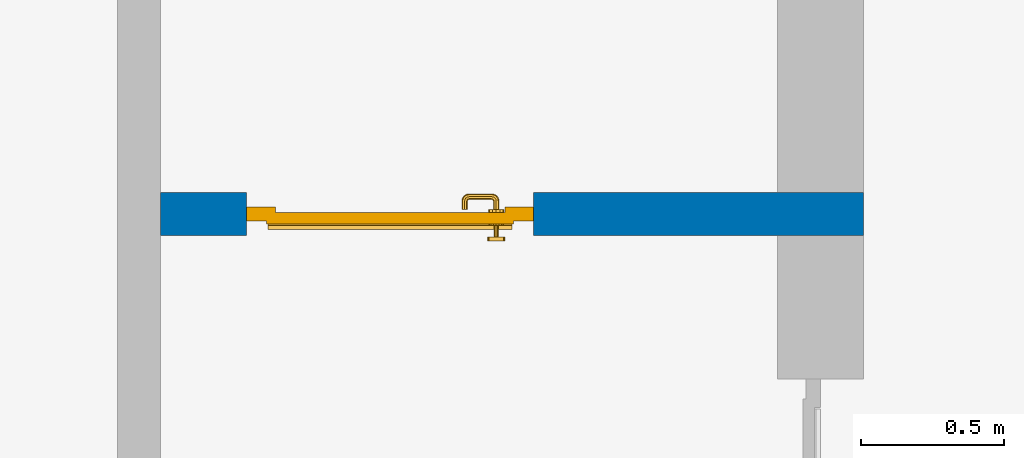
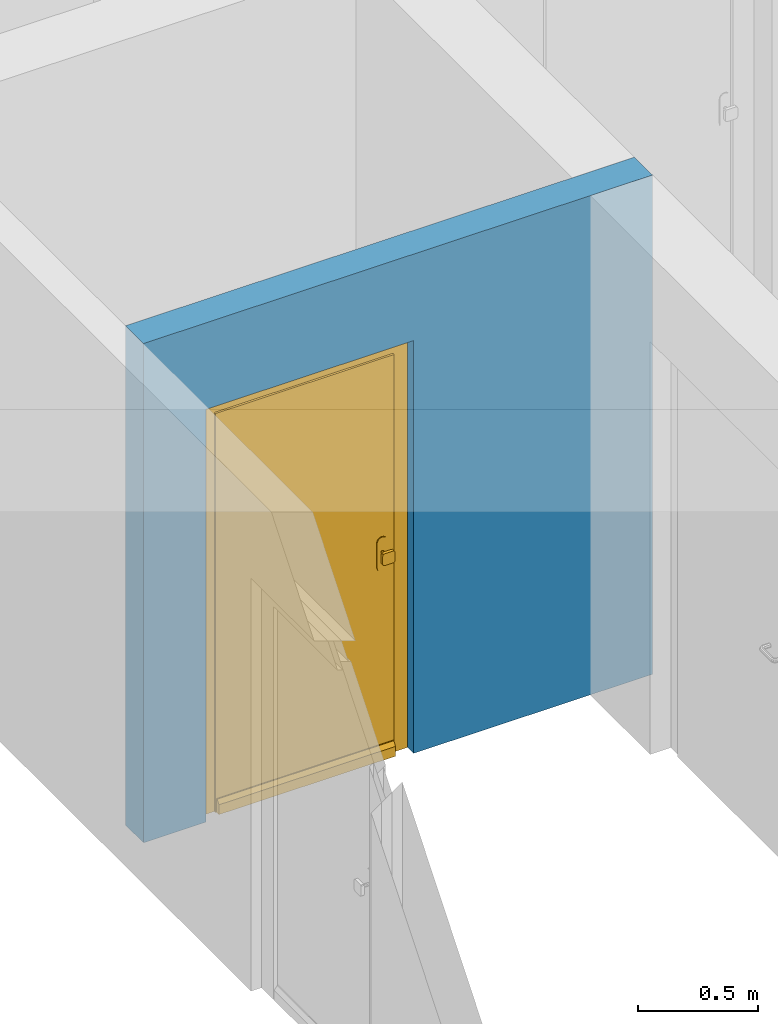
# One storey, part 5 of 54: 1 door, 1 wall, 1 opening.
"""IFC4 building model written with IfcOpenShell, lengths in metres."""

from ifc_helpers import new_model, entity, si_unit, converted_unit, derived_unit, direction, frame, origin_with_axes, place, context, subcontext, project, spatial, polygons, source, transform, mapped, material, type_object, element, fill, save


model = new_model("IFC4")

# Units and contexts
model_context = context("Model", 3, precision=1e-05, world=origin_with_axes(), true_north=direction((0.0, 1.0)))
body_context = subcontext(model_context, "Body", "Model", "MODEL_VIEW")
ifc_project = project(units=[si_unit("LENGTHUNIT", "METRE"), si_unit("AREAUNIT", "SQUARE_METRE"), si_unit("VOLUMEUNIT", "CUBIC_METRE"), converted_unit("PLANEANGLEUNIT", "DEGREE", entity("IfcPlaneAngleMeasure", 0.0174532925199), si_unit("PLANEANGLEUNIT", "RADIAN"), dimensions=[0, 0, 0, 0, 0, 0, 0]), converted_unit("TIMEUNIT", "Year", entity("IfcTimeMeasure", 31556926.0), si_unit("TIMEUNIT", "SECOND"), dimensions=[0, 0, 1, 0, 0, 0, 0]), si_unit("MASSUNIT", "GRAM", prefix="KILO"), si_unit("THERMODYNAMICTEMPERATUREUNIT", "DEGREE_CELSIUS"), si_unit("LUMINOUSINTENSITYUNIT", "LUMEN"), si_unit("ENERGYUNIT", "JOULE", prefix="MEGA"), derived_unit("THERMALCONDUCTANCEUNIT", [(si_unit("POWERUNIT", "WATT"), 1), (si_unit("LENGTHUNIT", "METRE"), -1), (si_unit("THERMODYNAMICTEMPERATUREUNIT", "KELVIN"), -1)]), derived_unit("SPECIFICHEATCAPACITYUNIT", [(si_unit("ENERGYUNIT", "JOULE"), 1), (si_unit("MASSUNIT", "GRAM", prefix="KILO"), -1), (si_unit("THERMODYNAMICTEMPERATUREUNIT", "KELVIN"), -1)]), derived_unit("MASSDENSITYUNIT", [(si_unit("MASSUNIT", "GRAM", prefix="KILO"), 1), (si_unit("VOLUMEUNIT", "CUBIC_METRE"), -1)])], contexts=[model_context])

# Site, building, storey
site_placement = place(None, origin_with_axes())
site = spatial("IfcSite", under=ifc_project, at=site_placement, CompositionType="ELEMENT")
building_placement = place(site_placement, origin_with_axes())
building = spatial("IfcBuilding", under=site, at=building_placement, CompositionType="ELEMENT")
storey_placement = place(building_placement, frame((0.0, 0.0, 9.18), z_axis=(0.0, 0.0, 1.0), x_axis=(1.0, 0.0, 0.0)))
storey = spatial("IfcBuildingStorey", under=building, at=storey_placement, Name="3. Geschoss", CompositionType="ELEMENT", Elevation=9.18)

# Wall, opening, door
ifc_material = material()
wall_type = type_object("IfcWallType", Name="150", PredefinedType="NOTDEFINED")
wall_placement = place(storey_placement, frame((-4.9421993804, -0.428812231043, 0.0), z_axis=(0.0, 0.0, 1.0), x_axis=(-1.0, 0.0, 0.0)))
wall = element("IfcWall", 1, at=wall_placement, inside=storey, type_object=wall_type, material=ifc_material, Name="Wand-002", PredefinedType="NOTDEFINED", context=body_context, shape_type="Tessellation", body=[
    polygons([(2.15, 0.0, 2.1), (2.15, 0.0, 0.0), (2.45, 0.0, 0.0), (2.45, 0.0, 2.54), (0.0, 0.0, 2.54), (0.0, 0.0, 0.0), (1.15, 0.0, 0.0), (1.15, 0.0, 2.1), (2.15, 0.1, 0.0), (2.15, 0.15, 2.1), (2.15, 0.15, 0.0), (2.45, 0.15, 0.0), (2.45, 0.15, 2.54), (0.0, 0.15, 2.54), (0.0, 0.15, 0.0), (1.15, 0.1, 0.0), (1.15, 0.15, 0.0), (1.15, 0.15, 2.1)], [[[1, 2, 3, 4, 5, 6, 7, 8]], [[9, 2, 1, 10, 11]], [[2, 9, 11, 12, 3]], [[4, 3, 12, 13]], [[5, 4, 13, 14]], [[14, 15, 6, 5]], [[16, 7, 6, 15, 17]], [[8, 7, 16, 17, 18]], [[1, 8, 18, 10]], [[12, 11, 10, 18, 17, 15, 14, 13]]], closed=True),
])
opening_placement = place(wall_placement, frame((1.65, 0.0, 0.0), z_axis=(0.0, 0.0, 1.0), x_axis=(1.0, 0.0, 0.0)))
opening = element("IfcOpeningElement", 2, at=opening_placement, cuts=wall, context=body_context, identifier="Reference", shape_type="Tessellation", body=[
    polygons([(-0.5, 0.1, 0.0), (-0.5, 0.1, 2.1), (-0.5, 0.151, 2.1), (-0.5, 0.151, 0.0), (-0.5, -0.001, 0.0), (-0.5, -0.001, 2.1), (0.5, 0.1, 2.1), (0.5, 0.151, 2.1), (0.5, -0.001, 2.1), (0.5, 0.151, 0.0), (0.5, 0.1, 0.0), (0.5, -0.001, 0.0)], [[[1, 2, 3, 4]], [[2, 1, 5, 6]], [[7, 8, 3, 2, 6, 9]], [[8, 10, 4, 3]], [[1, 4, 10, 11, 12, 5]], [[6, 5, 12, 9]], [[7, 11, 10, 8]], [[11, 7, 9, 12]]], closed=True),
])
door_type = type_object("IfcDoorType", Name="Eingang 01 1-Fl 26", OperationType="SINGLE_SWING_RIGHT", PredefinedType="DOOR")
shared_shape = source(origin_with_axes(), body_context, "Body", "Tessellation", [
    polygons([(0.5, -0.05, 0.0), (0.5, -0.03, 0.0), (0.5, -0.03, 2.1), (0.5, -0.05, 2.1), (0.4, -0.05, 0.0), (0.4, -0.03, 0.0), (0.4, -0.03, 2.0), (0.1301, -0.03, 2.0), (0.0001, -0.03, 2.0), (-0.4, -0.03, 2.0), (-0.4, -0.03, 0.0), (-0.5, -0.03, 0.0), (-0.5, -0.03, 2.1), (-0.5, -0.05, 2.1), (-0.5, -0.05, 0.0), (-0.4, -0.05, 0.0), (-0.4, -0.05, 2.0), (0.0001, -0.05, 2.0), (0.1301, -0.05, 2.0), (0.4, -0.05, 2.0)], [[[1, 2, 3, 4]], [[5, 6, 2, 1]], [[2, 6, 7, 8, 9, 10, 11, 12, 13, 3]], [[4, 3, 13, 14]], [[1, 4, 14, 15, 16, 17, 18, 19, 20, 5]], [[20, 7, 6, 5]], [[19, 8, 7, 20]], [[18, 9, 8, 19]], [[17, 10, 9, 18]], [[16, 11, 10, 17]], [[15, 12, 11, 16]], [[14, 13, 12, 15]]], closed=True),
    polygons([(0.5, -0.03, 0.0), (0.5, 0.0, 0.0), (0.5, 0.0, 2.1), (0.5, -0.03, 2.1), (0.43, -0.03, 0.0), (0.43, 0.0, 0.0), (0.43, 0.0, 2.03), (0.1001, 0.0, 2.03), (0.0301, 0.0, 2.03), (-0.43, 0.0, 2.03), (-0.43, 0.0, 0.0), (-0.5, 0.0, 0.0), (-0.5, 0.0, 2.1), (-0.5, -0.03, 2.1), (-0.5, -0.03, 0.0), (-0.43, -0.03, 0.0), (-0.43, -0.03, 2.03), (0.0301, -0.03, 2.03), (0.1001, -0.03, 2.03), (0.43, -0.03, 2.03)], [[[1, 2, 3, 4]], [[5, 6, 2, 1]], [[2, 6, 7, 8, 9, 10, 11, 12, 13, 3]], [[4, 3, 13, 14]], [[1, 4, 14, 15, 16, 17, 18, 19, 20, 5]], [[20, 7, 6, 5]], [[19, 8, 7, 20]], [[18, 9, 8, 19]], [[17, 10, 9, 18]], [[16, 11, 10, 17]], [[15, 12, 11, 16]], [[14, 13, 12, 15]]], closed=True),
    polygons([(0.43, 0.01, 0.0), (-0.43, 0.01, 0.0), (-0.43, 0.01, 2.03), (0.43, 0.01, 2.03), (0.43, -0.03, 0.0), (-0.43, -0.03, 0.0), (-0.43, -0.03, 2.03), (0.43, -0.03, 2.03)], [[[1, 2, 3, 4]], [[2, 1, 5, 6]], [[3, 2, 6, 7]], [[4, 3, 7, 8]], [[1, 4, 8, 5]], [[6, 5, 8, 7]]], closed=True),
    polygons([(0.425, 0.03, 0.0), (-0.425, 0.03, 0.0), (-0.425, 0.03, 0.05), (0.425, 0.03, 0.05), (0.425, 0.01, 0.0), (-0.425, 0.01, 0.0), (-0.425, 0.01, 0.07), (-0.425, 0.015, 0.07), (0.425, 0.015, 0.07), (0.425, 0.01, 0.07)], [[[1, 2, 3, 4]], [[5, 6, 2, 1]], [[2, 6, 7, 8, 3]], [[4, 3, 8, 9]], [[1, 4, 9, 10, 5]], [[10, 7, 6, 5]], [[9, 8, 7, 10]]], closed=True),
    polygons([(-0.3835, -0.04, 1.0733826859), (-0.37, -0.04, 1.077), (-0.37, -0.0399, 1.077), (-0.3835, -0.0399, 1.0733826859), (-0.393382685902, -0.04, 1.0635), (-0.397, -0.04, 1.05), (-0.393382685902, -0.04, 1.0365), (-0.3835, -0.04, 1.0266173141), (-0.37, -0.04, 1.023), (-0.3565, -0.04, 1.0266173141), (-0.346617314098, -0.04, 1.0365), (-0.343, -0.04, 1.05), (-0.346617314098, -0.04, 1.0635), (-0.3565, -0.04, 1.0733826859), (-0.3565, -0.0399, 1.0733826859), (-0.37, -0.0301, 1.077), (-0.3835, -0.0301, 1.0733826859), (-0.393382685902, -0.0399, 1.0635), (-0.397, -0.0399, 1.05), (-0.393382685902, -0.0399, 1.0365), (-0.3835, -0.0399, 1.0266173141), (-0.37, -0.0399, 1.023), (-0.3565, -0.0399, 1.0266173141), (-0.346617314098, -0.0399, 1.0365), (-0.343, -0.0399, 1.05), (-0.346617314098, -0.0399, 1.0635), (-0.3565, -0.0301, 1.0733826859), (-0.37, -0.03, 1.077), (-0.3835, -0.03, 1.0733826859), (-0.393382685902, -0.0301, 1.0635), (-0.397, -0.0301, 1.05), (-0.393382685902, -0.0301, 1.0365), (-0.3835, -0.0301, 1.0266173141), (-0.37, -0.0301, 1.023), (-0.3565, -0.0301, 1.0266173141), (-0.346617314098, -0.0301, 1.0365), (-0.343, -0.0301, 1.05), (-0.346617314098, -0.0301, 1.0635), (-0.3565, -0.03, 1.0733826859), (-0.346617314098, -0.03, 1.0635), (-0.343, -0.03, 1.05), (-0.346617314098, -0.03, 1.0365), (-0.3565, -0.03, 1.0266173141), (-0.37, -0.03, 1.023), (-0.3835, -0.03, 1.0266173141), (-0.393382685902, -0.03, 1.0365), (-0.397, -0.03, 1.05), (-0.393382685902, -0.03, 1.0635)], [[[1, 2, 3, 4]], [[2, 1, 5, 6, 7, 8, 9, 10, 11, 12, 13, 14]], [[2, 14, 15, 3]], [[4, 3, 16, 17]], [[5, 1, 4, 18]], [[6, 5, 18, 19]], [[7, 6, 19, 20]], [[8, 7, 20, 21]], [[9, 8, 21, 22]], [[10, 9, 22, 23]], [[11, 10, 23, 24]], [[12, 11, 24, 25]], [[13, 12, 25, 26]], [[14, 13, 26, 15]], [[3, 15, 27, 16]], [[17, 16, 28, 29]], [[18, 4, 17, 30]], [[19, 18, 30, 31]], [[20, 19, 31, 32]], [[21, 20, 32, 33]], [[22, 21, 33, 34]], [[23, 22, 34, 35]], [[24, 23, 35, 36]], [[25, 24, 36, 37]], [[26, 25, 37, 38]], [[15, 26, 38, 27]], [[16, 27, 39, 28]], [[28, 39, 40, 41, 42, 43, 44, 45, 46, 47, 48, 29]], [[30, 17, 29, 48]], [[31, 30, 48, 47]], [[32, 31, 47, 46]], [[33, 32, 46, 45]], [[34, 33, 45, 44]], [[35, 34, 44, 43]], [[36, 35, 43, 42]], [[37, 36, 42, 41]], [[38, 37, 41, 40]], [[27, 38, 40, 39]]], closed=True),
    polygons([(-0.362532169224, -0.04, 0.959692280177), (-0.365, -0.04, 0.9544), (-0.365, -0.04, 0.952886751346), (-0.346703916638, -0.04, 0.96345), (-0.35655, -0.04, 0.973296083362), (-0.363279754556, -0.04, 0.961639806549), (-0.362532169224, -0.039, 0.959692280177), (-0.365, -0.039, 0.9544), (-0.365, -0.039, 0.952886751346), (-0.365, -0.039, 0.95), (-0.365, -0.039, 0.947113248654), (-0.365, -0.039, 0.941339745962), (-0.365, -0.039, 0.9375), (-0.365, -0.04, 0.9375), (-0.365, -0.04, 0.941339745962), (-0.365, -0.04, 0.947113248654), (-0.365, -0.04, 0.95), (-0.3431, -0.04, 0.95), (-0.346617314098, -0.04, 0.9635), (-0.3565, -0.04, 0.973382685902), (-0.364624817685, -0.04, 0.965143815798), (-0.37, -0.04, 0.9769), (-0.37, -0.04, 0.967425445323), (-0.364624817685, -0.039, 0.965143815798), (-0.363279754556, -0.039, 0.961639806549), (-0.35705, -0.039, 0.972430057958), (-0.347569942042, -0.039, 0.96295), (-0.3441, -0.039, 0.95), (-0.347569942042, -0.039, 0.93705), (-0.35705, -0.039, 0.927569942042), (-0.37, -0.039, 0.9241), (-0.37, -0.039, 0.9325), (-0.366464466094, -0.039, 0.933964466094), (-0.366464466094, -0.04, 0.933964466094), (-0.35655, -0.04, 0.926703916638), (-0.37, -0.04, 0.9325), (-0.37, -0.04, 0.9231), (-0.346703916638, -0.04, 0.93655), (-0.343, -0.04, 0.95), (-0.346617314098, -0.0399, 0.9635), (-0.3565, -0.0399, 0.973382685902), (-0.37, -0.04, 0.977), (-0.375375182315, -0.04, 0.965143815798), (-0.38345, -0.04, 0.973296083362), (-0.376720245444, -0.04, 0.961639806549), (-0.37, -0.039, 0.967425445323), (-0.37, -0.039, 0.9759), (-0.357, -0.039, 0.972516660498), (-0.347483339502, -0.039, 0.963), (-0.344, -0.039, 0.95), (-0.347483339502, -0.039, 0.937), (-0.357, -0.039, 0.927483339502), (-0.38295, -0.039, 0.927569942042), (-0.375, -0.039, 0.941339745962), (-0.375, -0.039, 0.9375), (-0.373535533906, -0.039, 0.933964466094), (-0.37, -0.039, 0.924), (-0.373535533906, -0.04, 0.933964466094), (-0.375, -0.04, 0.9375), (-0.375, -0.04, 0.941339745962), (-0.38345, -0.04, 0.926703916638), (-0.37, -0.04, 0.923), (-0.3565, -0.04, 0.926617314098), (-0.346617314098, -0.04, 0.9365), (-0.343, -0.0399, 0.95), (-0.346617314098, -0.0301, 0.9635), (-0.3565, -0.0301, 0.973382685902), (-0.37, -0.0399, 0.977), (-0.3835, -0.04, 0.973382685902), (-0.375375182315, -0.039, 0.965143815798), (-0.377467830776, -0.04, 0.959692280177), (-0.393296083362, -0.04, 0.96345), (-0.375, -0.04, 0.952886751346), (-0.375, -0.04, 0.9544), (-0.377467830776, -0.039, 0.959692280177), (-0.376720245444, -0.039, 0.961639806549), (-0.38295, -0.039, 0.972430057958), (-0.37, -0.039, 0.976), (-0.357, -0.0389, 0.972516660498), (-0.347483339502, -0.0389, 0.963), (-0.344, -0.0389, 0.95), (-0.347483339502, -0.0389, 0.937), (-0.357, -0.0389, 0.927483339502), (-0.392430057958, -0.039, 0.93705), (-0.375, -0.039, 0.947113248654), (-0.375, -0.039, 0.9544), (-0.375, -0.04, 0.95), (-0.375, -0.04, 0.947113248654), (-0.375, -0.039, 0.95), (-0.375, -0.039, 0.952886751346), (-0.383, -0.039, 0.927483339502), (-0.37, -0.0389, 0.924), (-0.393296083362, -0.04, 0.93655), (-0.3835, -0.04, 0.926617314098), (-0.37, -0.0399, 0.923), (-0.3565, -0.0399, 0.926617314098), (-0.346617314098, -0.0399, 0.9365), (-0.343, -0.0301, 0.95), (-0.346617314098, -0.03, 0.9635), (-0.3565, -0.03, 0.973382685902), (-0.37, -0.0301, 0.977), (-0.3835, -0.0399, 0.973382685902), (-0.393382685902, -0.04, 0.9635), (-0.3969, -0.04, 0.95), (-0.392430057958, -0.039, 0.96295), (-0.383, -0.039, 0.972516660498), (-0.37, -0.0389, 0.976), (-0.357, -0.0301, 0.972516660498), (-0.347483339502, -0.0301, 0.963), (-0.344, -0.0301, 0.95), (-0.347483339502, -0.0301, 0.937), (-0.357, -0.0301, 0.927483339502), (-0.392516660498, -0.039, 0.937), (-0.3959, -0.039, 0.95), (-0.383, -0.0389, 0.927483339502), (-0.37, -0.0301, 0.924), (-0.393382685902, -0.04, 0.9365), (-0.3835, -0.0399, 0.926617314098), (-0.37, -0.0301, 0.923), (-0.3565, -0.0301, 0.926617314098), (-0.346617314098, -0.0301, 0.9365), (-0.343, -0.03, 0.95), (-0.346703916638, -0.03, 0.96345), (-0.35655, -0.03, 0.973296083362), (-0.37, -0.03, 0.977), (-0.3835, -0.0301, 0.973382685902), (-0.393382685902, -0.0399, 0.9635), (-0.397, -0.04, 0.95), (-0.392516660498, -0.039, 0.963), (-0.383, -0.0389, 0.972516660498), (-0.37, -0.0301, 0.976), (-0.357, -0.03, 0.972516660498), (-0.347483339502, -0.03, 0.963), (-0.344, -0.03, 0.95), (-0.347483339502, -0.03, 0.937), (-0.357, -0.03, 0.927483339502), (-0.392516660498, -0.0389, 0.937), (-0.396, -0.039, 0.95), (-0.383, -0.0301, 0.927483339502), (-0.37, -0.03, 0.924), (-0.393382685902, -0.0399, 0.9365), (-0.3835, -0.0301, 0.926617314098), (-0.37, -0.03, 0.923), (-0.3565, -0.03, 0.926617314098), (-0.346617314098, -0.03, 0.9365), (-0.3431, -0.03, 0.95), (-0.347396736961, -0.03, 0.96305), (-0.35695, -0.03, 0.972603263039), (-0.37, -0.03, 0.9769), (-0.3835, -0.03, 0.973382685902), (-0.393382685902, -0.0301, 0.9635), (-0.397, -0.0399, 0.95), (-0.392516660498, -0.0389, 0.963), (-0.383, -0.0301, 0.972516660498), (-0.37, -0.03, 0.976), (-0.3439, -0.03, 0.95), (-0.347396736961, -0.03, 0.93695), (-0.35695, -0.03, 0.927396736961), (-0.392516660498, -0.0301, 0.937), (-0.396, -0.0389, 0.95), (-0.383, -0.03, 0.927483339502), (-0.37, -0.03, 0.9239), (-0.393382685902, -0.0301, 0.9365), (-0.3835, -0.03, 0.926617314098), (-0.37, -0.03, 0.9231), (-0.35655, -0.03, 0.926703916638), (-0.346703916638, -0.03, 0.93655), (-0.37, -0.03, 0.9761), (-0.38345, -0.03, 0.973296083362), (-0.393382685902, -0.03, 0.9635), (-0.397, -0.0301, 0.95), (-0.392516660498, -0.0301, 0.963), (-0.383, -0.03, 0.972516660498), (-0.392516660498, -0.03, 0.937), (-0.396, -0.0301, 0.95), (-0.38305, -0.03, 0.927396736961), (-0.393382685902, -0.03, 0.9365), (-0.38345, -0.03, 0.926703916638), (-0.38305, -0.03, 0.972603263039), (-0.393296083362, -0.03, 0.96345), (-0.397, -0.03, 0.95), (-0.392516660498, -0.03, 0.963), (-0.392603263039, -0.03, 0.93695), (-0.396, -0.03, 0.95), (-0.393296083362, -0.03, 0.93655), (-0.392603263039, -0.03, 0.96305), (-0.3969, -0.03, 0.95), (-0.3961, -0.03, 0.95)], [[[1, 2, 3, 4, 5, 6]], [[2, 1, 7, 8]], [[2, 8, 9, 10, 11, 12, 13, 14, 15, 16, 17, 3]], [[17, 18, 4, 3]], [[19, 20, 5, 4]], [[21, 6, 5, 22, 23]], [[1, 6, 21, 24, 25, 7]], [[7, 25, 26, 27, 9, 8]], [[9, 27, 28, 10]], [[10, 28, 29, 11]], [[11, 29, 30, 12]], [[31, 32, 33, 13, 12, 30]], [[14, 13, 33, 34]], [[35, 15, 14, 34, 36, 37]], [[15, 35, 38, 16]], [[16, 38, 18, 17]], [[39, 19, 4, 18]], [[40, 41, 20, 19]], [[20, 42, 22, 5]], [[43, 23, 22, 44, 45]], [[21, 23, 46, 24]], [[24, 46, 47, 26, 25]], [[27, 26, 48, 49]], [[28, 27, 49, 50]], [[29, 28, 50, 51]], [[30, 29, 51, 52]], [[53, 54, 55, 56, 32, 31]], [[34, 33, 32, 36]], [[31, 30, 52, 57]], [[37, 36, 58, 59, 60, 61]], [[62, 63, 35, 37]], [[63, 64, 38, 35]], [[64, 39, 18, 38]], [[65, 40, 19, 39]], [[66, 67, 41, 40]], [[41, 68, 42, 20]], [[42, 69, 44, 22]], [[23, 43, 70, 46]], [[71, 45, 44, 72, 73, 74]], [[43, 45, 71, 75, 76, 70]], [[70, 76, 77, 47, 46]], [[26, 47, 78, 48]], [[49, 48, 79, 80]], [[50, 49, 80, 81]], [[51, 50, 81, 82]], [[52, 51, 82, 83]], [[54, 53, 84, 85]], [[86, 74, 73, 87, 88, 60, 59, 55, 54, 85, 89, 90]], [[58, 56, 55, 59]], [[36, 32, 56, 58]], [[53, 31, 57, 91]], [[57, 52, 83, 92]], [[88, 93, 61, 60]], [[94, 62, 37, 61]], [[95, 96, 63, 62]], [[96, 97, 64, 63]], [[97, 65, 39, 64]], [[98, 66, 40, 65]], [[99, 100, 67, 66]], [[67, 101, 68, 41]], [[68, 102, 69, 42]], [[69, 103, 72, 44]], [[73, 72, 104, 87]], [[71, 74, 86, 75]], [[75, 86, 90, 105, 77, 76]], [[47, 77, 106, 78]], [[48, 78, 107, 79]], [[80, 79, 108, 109]], [[81, 80, 109, 110]], [[82, 81, 110, 111]], [[83, 82, 111, 112]], [[84, 53, 91, 113]], [[85, 84, 114, 89]], [[87, 104, 93, 88]], [[89, 114, 105, 90]], [[91, 57, 92, 115]], [[92, 83, 112, 116]], [[117, 94, 61, 93]], [[118, 95, 62, 94]], [[119, 120, 96, 95]], [[120, 121, 97, 96]], [[121, 98, 65, 97]], [[122, 99, 66, 98]], [[123, 124, 100, 99]], [[100, 125, 101, 67]], [[101, 126, 102, 68]], [[102, 127, 103, 69]], [[103, 128, 104, 72]], [[77, 105, 129, 106]], [[78, 106, 130, 107]], [[79, 107, 131, 108]], [[109, 108, 132, 133]], [[110, 109, 133, 134]], [[111, 110, 134, 135]], [[112, 111, 135, 136]], [[113, 91, 115, 137]], [[114, 84, 113, 138]], [[128, 117, 93, 104]], [[105, 114, 138, 129]], [[115, 92, 116, 139]], [[116, 112, 136, 140]], [[141, 118, 94, 117]], [[142, 119, 95, 118]], [[143, 144, 120, 119]], [[144, 145, 121, 120]], [[145, 122, 98, 121]], [[146, 123, 99, 122]], [[147, 148, 124, 123]], [[124, 149, 125, 100]], [[125, 150, 126, 101]], [[126, 151, 127, 102]], [[127, 152, 128, 103]], [[106, 129, 153, 130]], [[107, 130, 154, 131]], [[108, 131, 155, 132]], [[133, 132, 148, 147]], [[134, 133, 147, 156]], [[135, 134, 156, 157]], [[136, 135, 157, 158]], [[137, 115, 139, 159]], [[138, 113, 137, 160]], [[152, 141, 117, 128]], [[129, 138, 160, 153]], [[139, 116, 140, 161]], [[140, 136, 158, 162]], [[163, 142, 118, 141]], [[164, 143, 119, 142]], [[165, 166, 144, 143]], [[166, 167, 145, 144]], [[167, 146, 122, 145]], [[156, 147, 123, 146]], [[148, 168, 149, 124]], [[149, 169, 150, 125]], [[150, 170, 151, 126]], [[151, 171, 152, 127]], [[130, 153, 172, 154]], [[131, 154, 173, 155]], [[132, 155, 168, 148]], [[157, 156, 146, 167]], [[158, 157, 167, 166]], [[159, 139, 161, 174]], [[160, 137, 159, 175]], [[171, 163, 141, 152]], [[153, 160, 175, 172]], [[161, 140, 162, 176]], [[162, 158, 166, 165]], [[177, 164, 142, 163]], [[178, 165, 143, 164]], [[168, 179, 169, 149]], [[169, 180, 170, 150]], [[170, 181, 171, 151]], [[154, 172, 182, 173]], [[155, 173, 179, 168]], [[174, 161, 176, 183]], [[175, 159, 174, 184]], [[181, 177, 163, 171]], [[172, 175, 184, 182]], [[176, 162, 165, 178]], [[185, 178, 164, 177]], [[179, 186, 180, 169]], [[180, 187, 181, 170]], [[173, 182, 186, 179]], [[183, 176, 178, 185]], [[184, 174, 183, 188]], [[187, 185, 177, 181]], [[182, 184, 188, 186]], [[186, 188, 187, 180]], [[188, 183, 185, 187]]], closed=True),
    polygons([(-0.38, -0.04, 1.05), (-0.377071067812, -0.04, 1.04292893219), (-0.377071067812, -0.070696439392, 1.04292893219), (-0.38, -0.0709849140336, 1.05), (-0.37, -0.04, 1.04), (-0.37, -0.07, 1.04), (-0.375518993221, -0.0784992452783, 1.04292893219), (-0.378277987014, -0.0796420579258, 1.05), (-0.377071067812, -0.04, 1.05707106781), (-0.377071067812, -0.070696439392, 1.05707106781), (-0.362928932188, -0.04, 1.04292893219), (-0.362928932188, -0.069303560608, 1.04292893219), (-0.368858192988, -0.0757402514855, 1.04), (-0.370704557509, -0.0857045575088, 1.04292893219), (-0.372816199938, -0.0878161999379, 1.05), (-0.375518993221, -0.0784992452783, 1.05707106781), (-0.37, -0.04, 1.06), (-0.37, -0.07, 1.06), (-0.36, -0.04, 1.05), (-0.36, -0.0690150859664, 1.05), (-0.362197392755, -0.0729812576926, 1.04292893219), (-0.365606601718, -0.0806066017178, 1.04), (-0.363499245278, -0.0905189932208, 1.04292893219), (-0.364642057926, -0.0932779870137, 1.05), (-0.370704557509, -0.0857045575088, 1.05707106781), (-0.368858192988, -0.0757402514855, 1.06), (-0.362928932188, -0.04, 1.05707106781), (-0.362928932188, -0.069303560608, 1.05707106781), (-0.359438398962, -0.0718384450452, 1.05), (-0.360508645927, -0.0755086459268, 1.04292893219), (-0.360740251485, -0.0838581929877, 1.04), (-0.355696439392, -0.0920710678119, 1.04292893219), (-0.355984914034, -0.095, 1.05), (-0.363499245278, -0.0905189932208, 1.05707106781), (-0.365606601718, -0.0806066017178, 1.06), (-0.362197392755, -0.0729812576926, 1.05707106781), (-0.358397003498, -0.0733970034977, 1.05), (-0.357981257693, -0.0771973927545, 1.04292893219), (-0.355, -0.085, 1.04), (-0.274303560608, -0.0920710678119, 1.04292893219), (-0.274015085966, -0.095, 1.05), (-0.355696439392, -0.0920710678119, 1.05707106781), (-0.360740251485, -0.0838581929877, 1.06), (-0.360508645927, -0.0755086459268, 1.05707106781), (-0.356838445045, -0.0744383989617, 1.05), (-0.354303560608, -0.0779289321881, 1.04292893219), (-0.275, -0.085, 1.04), (-0.266500754722, -0.0905189932208, 1.04292893219), (-0.265357942074, -0.0932779870137, 1.05), (-0.274303560608, -0.0920710678119, 1.05707106781), (-0.355, -0.085, 1.06), (-0.357981257693, -0.0771973927545, 1.05707106781), (-0.354015085966, -0.075, 1.05), (-0.275696439392, -0.0779289321881, 1.04292893219), (-0.269259748515, -0.0838581929877, 1.04), (-0.259295442491, -0.0857045575088, 1.04292893219), (-0.257183800062, -0.0878161999379, 1.05), (-0.266500754722, -0.0905189932208, 1.05707106781), (-0.275, -0.085, 1.06), (-0.354303560608, -0.0779289321881, 1.05707106781), (-0.275984914034, -0.075, 1.05), (-0.272018742307, -0.0771973927545, 1.04292893219), (-0.264393398282, -0.0806066017178, 1.04), (-0.254481006779, -0.0784992452783, 1.04292893219), (-0.251722012986, -0.0796420579258, 1.05), (-0.259295442491, -0.0857045575088, 1.05707106781), (-0.269259748515, -0.0838581929877, 1.06), (-0.275696439392, -0.0779289321881, 1.05707106781), (-0.273161554955, -0.0744383989617, 1.05), (-0.269491354073, -0.0755086459268, 1.04292893219), (-0.261141807012, -0.0757402514855, 1.04), (-0.252928932188, -0.070696439392, 1.04292893219), (-0.25, -0.0709849140336, 1.05), (-0.254481006779, -0.0784992452783, 1.05707106781), (-0.264393398282, -0.0806066017178, 1.06), (-0.272018742307, -0.0771973927545, 1.05707106781), (-0.271602996502, -0.0733970034977, 1.05), (-0.267802607245, -0.0729812576926, 1.04292893219), (-0.26, -0.07, 1.04), (-0.252928932188, -0.04, 1.04292893219), (-0.25, -0.04, 1.05), (-0.252928932188, -0.070696439392, 1.05707106781), (-0.261141807012, -0.0757402514855, 1.06), (-0.269491354073, -0.0755086459268, 1.05707106781), (-0.270561601038, -0.0718384450452, 1.05), (-0.267071067812, -0.069303560608, 1.04292893219), (-0.26, -0.04, 1.04), (-0.267071067812, -0.04, 1.04292893219), (-0.27, -0.04, 1.05), (-0.267071067812, -0.04, 1.05707106781), (-0.26, -0.04, 1.06), (-0.252928932188, -0.04, 1.05707106781), (-0.26, -0.07, 1.06), (-0.267802607245, -0.0729812576926, 1.05707106781), (-0.27, -0.0690150859664, 1.05), (-0.267071067812, -0.069303560608, 1.05707106781)], [[[1, 2, 3, 4]], [[2, 5, 6, 3]], [[4, 3, 7, 8]], [[9, 1, 4, 10]], [[5, 11, 12, 6]], [[3, 6, 13, 7]], [[8, 7, 14, 15]], [[10, 4, 8, 16]], [[17, 9, 10, 18]], [[11, 19, 20, 12]], [[6, 12, 21, 13]], [[7, 13, 22, 14]], [[15, 14, 23, 24]], [[16, 8, 15, 25]], [[18, 10, 16, 26]], [[27, 17, 18, 28]], [[19, 27, 28, 20]], [[12, 20, 29, 21]], [[13, 21, 30, 22]], [[14, 22, 31, 23]], [[24, 23, 32, 33]], [[25, 15, 24, 34]], [[26, 16, 25, 35]], [[28, 18, 26, 36]], [[20, 28, 36, 29]], [[21, 29, 37, 30]], [[22, 30, 38, 31]], [[23, 31, 39, 32]], [[33, 32, 40, 41]], [[34, 24, 33, 42]], [[35, 25, 34, 43]], [[36, 26, 35, 44]], [[29, 36, 44, 37]], [[30, 37, 45, 38]], [[31, 38, 46, 39]], [[32, 39, 47, 40]], [[41, 40, 48, 49]], [[42, 33, 41, 50]], [[43, 34, 42, 51]], [[44, 35, 43, 52]], [[37, 44, 52, 45]], [[38, 45, 53, 46]], [[39, 46, 54, 47]], [[40, 47, 55, 48]], [[49, 48, 56, 57]], [[50, 41, 49, 58]], [[51, 42, 50, 59]], [[52, 43, 51, 60]], [[45, 52, 60, 53]], [[46, 53, 61, 54]], [[47, 54, 62, 55]], [[48, 55, 63, 56]], [[57, 56, 64, 65]], [[58, 49, 57, 66]], [[59, 50, 58, 67]], [[60, 51, 59, 68]], [[53, 60, 68, 61]], [[54, 61, 69, 62]], [[55, 62, 70, 63]], [[56, 63, 71, 64]], [[65, 64, 72, 73]], [[66, 57, 65, 74]], [[67, 58, 66, 75]], [[68, 59, 67, 76]], [[61, 68, 76, 69]], [[62, 69, 77, 70]], [[63, 70, 78, 71]], [[64, 71, 79, 72]], [[73, 72, 80, 81]], [[74, 65, 73, 82]], [[75, 66, 74, 83]], [[76, 67, 75, 84]], [[69, 76, 84, 77]], [[70, 77, 85, 78]], [[71, 78, 86, 79]], [[72, 79, 87, 80]], [[81, 80, 87, 88, 89, 90, 91, 92]], [[82, 73, 81, 92]], [[83, 74, 82, 93]], [[84, 75, 83, 94]], [[77, 84, 94, 85]], [[78, 85, 95, 86]], [[79, 86, 88, 87]], [[86, 95, 89, 88]], [[95, 96, 90, 89]], [[96, 93, 91, 90]], [[93, 82, 92, 91]], [[94, 83, 93, 96]], [[85, 94, 96, 95]]], closed=False),
    polygons([(-0.364696699141, 0.015, 1.04469669914), (-0.3625, 0.015, 1.05), (-0.364696699141, 0.015, 1.05530330086), (-0.37, 0.015, 1.0575), (-0.375303300859, 0.015, 1.05530330086), (-0.3775, 0.015, 1.05), (-0.375303300859, 0.015, 1.04469669914), (-0.37, 0.015, 1.0425), (-0.364696699141, 0.055, 1.04469669914), (-0.3625, 0.055, 1.05), (-0.364696699141, 0.055, 1.05530330086), (-0.37, 0.055, 1.0575), (-0.375303300859, 0.055, 1.05530330086), (-0.3775, 0.055, 1.05), (-0.375303300859, 0.055, 1.04469669914), (-0.37, 0.055, 1.0425)], [[[1, 2, 3, 4, 5, 6, 7, 8]], [[1, 9, 10, 2]], [[2, 10, 11, 3]], [[3, 11, 12, 4]], [[4, 12, 13, 5]], [[5, 13, 14, 6]], [[6, 14, 15, 7]], [[7, 15, 16, 8]], [[8, 16, 9, 1]], [[9, 16, 15, 14, 13, 12, 11, 10]]], closed=True),
    polygons([(-0.395, 0.01, 0.975), (-0.395, 0.015, 0.975), (-0.393096988313, 0.015, 0.965432914191), (-0.393096988313, 0.01, 0.965432914191), (-0.395, 0.01, 1.1), (-0.395, 0.015, 1.1), (-0.393096988313, 0.015, 1.10956708581), (-0.38767766953, 0.015, 1.11767766953), (-0.379567085809, 0.015, 1.12309698831), (-0.37, 0.015, 1.125), (-0.360432914191, 0.015, 1.12309698831), (-0.35232233047, 0.015, 1.11767766953), (-0.346903011687, 0.015, 1.10956708581), (-0.345, 0.015, 1.1), (-0.345, 0.015, 0.975), (-0.346903011687, 0.015, 0.965432914191), (-0.35232233047, 0.015, 0.95732233047), (-0.360432914191, 0.015, 0.951903011687), (-0.37, 0.015, 0.95), (-0.379567085809, 0.015, 0.951903011687), (-0.38767766953, 0.015, 0.95732233047), (-0.38767766953, 0.01, 0.95732233047), (-0.379567085809, 0.01, 0.951903011687), (-0.37, 0.01, 0.95), (-0.360432914191, 0.01, 0.951903011687), (-0.35232233047, 0.01, 0.95732233047), (-0.346903011687, 0.01, 0.965432914191), (-0.345, 0.01, 0.975), (-0.345, 0.01, 1.1), (-0.346903011687, 0.01, 1.10956708581), (-0.35232233047, 0.01, 1.11767766953), (-0.360432914191, 0.01, 1.12309698831), (-0.37, 0.01, 1.125), (-0.379567085809, 0.01, 1.12309698831), (-0.38767766953, 0.01, 1.11767766953), (-0.393096988313, 0.01, 1.10956708581)], [[[1, 2, 3, 4]], [[5, 6, 2, 1]], [[2, 6, 7, 8, 9, 10, 11, 12, 13, 14, 15, 16, 17, 18, 19, 20, 21, 3]], [[4, 3, 21, 22]], [[1, 4, 22, 23, 24, 25, 26, 27, 28, 29, 30, 31, 32, 33, 34, 35, 36, 5]], [[36, 7, 6, 5]], [[35, 8, 7, 36]], [[34, 9, 8, 35]], [[33, 10, 9, 34]], [[32, 11, 10, 33]], [[31, 12, 11, 32]], [[30, 13, 12, 31]], [[29, 14, 13, 30]], [[28, 15, 14, 29]], [[27, 16, 15, 28]], [[26, 17, 16, 27]], [[25, 18, 17, 26]], [[24, 19, 18, 25]], [[23, 20, 19, 24]], [[22, 21, 20, 23]]], closed=True),
    polygons([(-0.39, 0.055, 1.08), (-0.39, 0.07, 1.08), (-0.395, 0.07, 1.07866025404), (-0.395, 0.055, 1.07866025404), (-0.35, 0.055, 1.08), (-0.35, 0.07, 1.08), (-0.345, 0.07, 1.07866025404), (-0.341339745962, 0.07, 1.075), (-0.34, 0.07, 1.07), (-0.34, 0.07, 1.03), (-0.341339745962, 0.07, 1.025), (-0.345, 0.07, 1.02133974596), (-0.35, 0.07, 1.02), (-0.39, 0.07, 1.02), (-0.395, 0.07, 1.02133974596), (-0.398660254038, 0.07, 1.025), (-0.4, 0.07, 1.03), (-0.4, 0.07, 1.07), (-0.398660254038, 0.07, 1.075), (-0.398660254038, 0.055, 1.075), (-0.4, 0.055, 1.07), (-0.4, 0.055, 1.03), (-0.398660254038, 0.055, 1.025), (-0.395, 0.055, 1.02133974596), (-0.39, 0.055, 1.02), (-0.35, 0.055, 1.02), (-0.345, 0.055, 1.02133974596), (-0.341339745962, 0.055, 1.025), (-0.34, 0.055, 1.03), (-0.34, 0.055, 1.07), (-0.341339745962, 0.055, 1.075), (-0.345, 0.055, 1.07866025404)], [[[1, 2, 3, 4]], [[5, 6, 2, 1]], [[2, 6, 7, 8, 9, 10, 11, 12, 13, 14, 15, 16, 17, 18, 19, 3]], [[4, 3, 19, 20]], [[1, 4, 20, 21, 22, 23, 24, 25, 26, 27, 28, 29, 30, 31, 32, 5]], [[32, 7, 6, 5]], [[31, 8, 7, 32]], [[30, 9, 8, 31]], [[29, 10, 9, 30]], [[28, 11, 10, 29]], [[27, 12, 11, 28]], [[26, 13, 12, 27]], [[25, 14, 13, 26]], [[24, 15, 14, 25]], [[23, 16, 15, 24]], [[22, 17, 16, 23]], [[21, 18, 17, 22]], [[20, 19, 18, 21]]], closed=True),
])
door_placement = place(opening_placement, frame((-0.4, 0.0, 0.0), z_axis=(0.0, 0.0, 1.0), x_axis=(1.0, 0.0, 0.0)))
door = element("IfcDoor", 3, at=door_placement, inside=storey, type_object=door_type, OverallHeight=2.1, OverallWidth=1.0, PredefinedType="DOOR", context=body_context, shape_type="MappedRepresentation", body=[
    mapped(shared_shape, transform((0.4, 0.1, 0.0))),
])
fill(opening, door)

save(model, "model.ifc")
